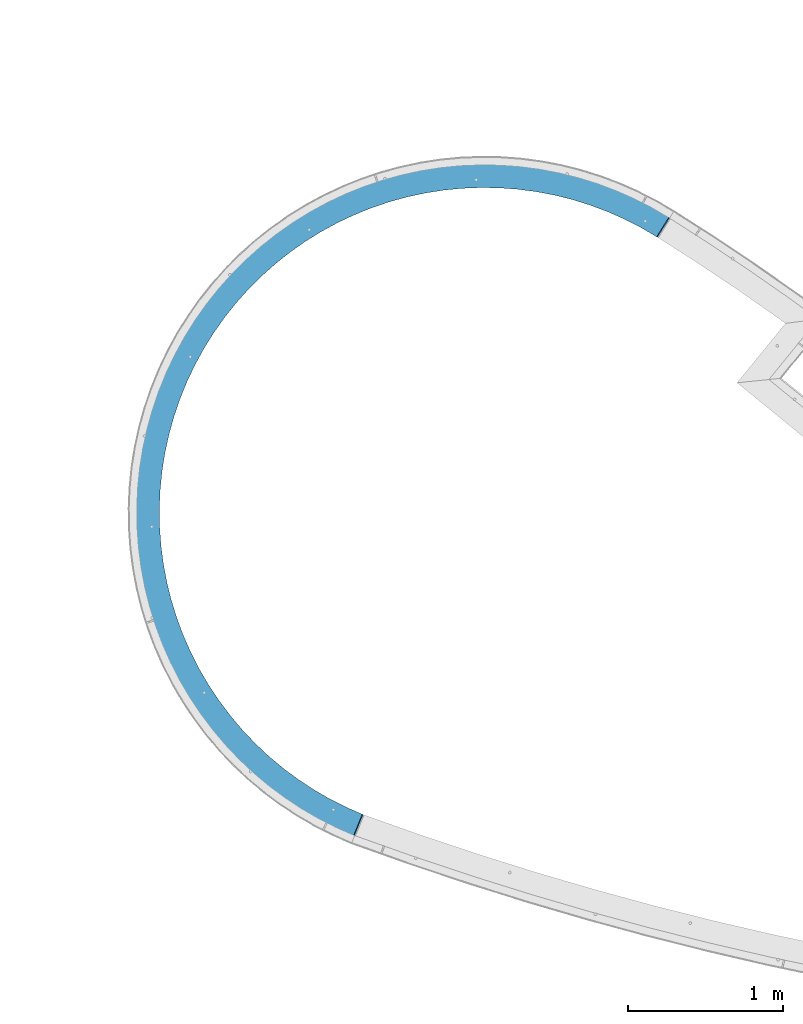
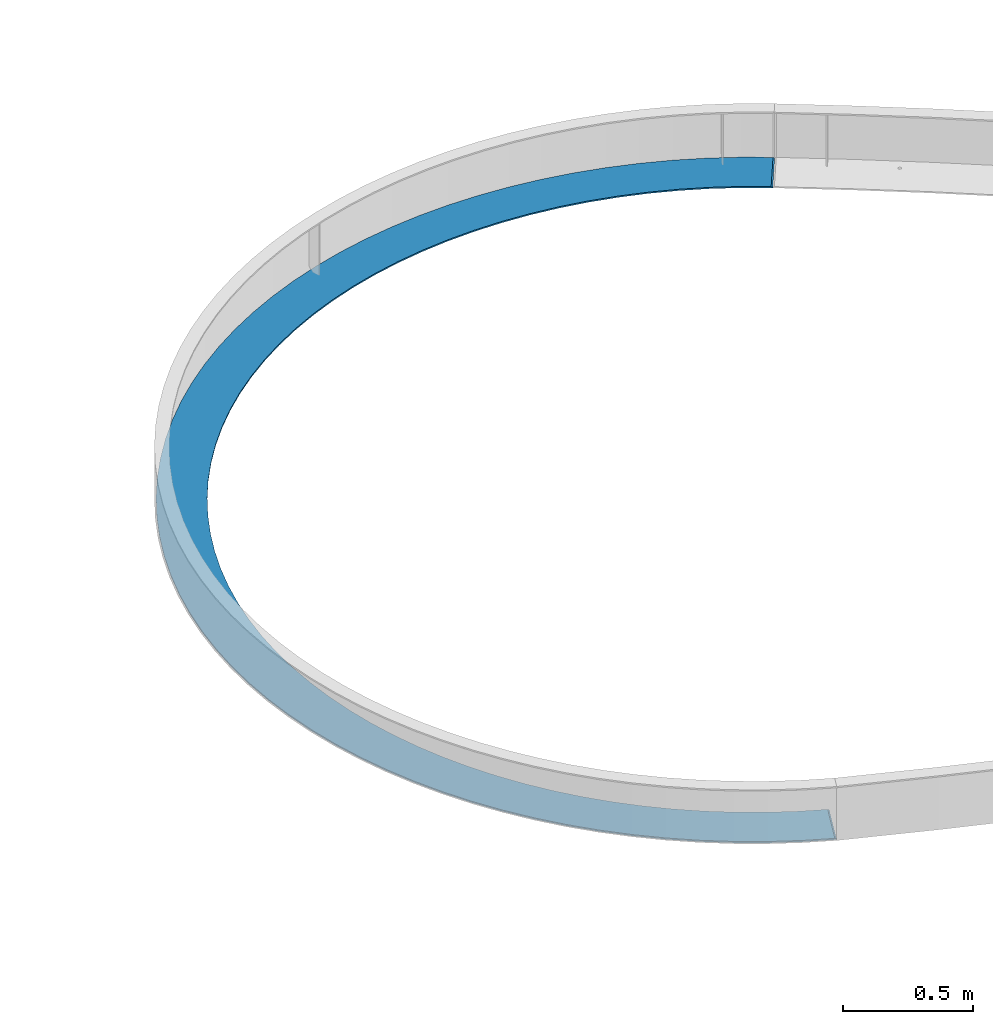
# One storey, part 1138 of 1763: 1 beam, 1 element without a shape of its own.
"""IFC2X3 building model written with IfcOpenShell, lengths in millimetres."""

from ifc_helpers import new_model, si_unit, frame, origin_with_axes, place, context, subcontext, project, spatial, faceted_brep, material, type_object, element, aggregate, save


model = new_model("IFC2X3")

# Units and contexts
model_context = context("Model", 3, precision=1e-05, world=origin_with_axes())
body_context = subcontext(model_context, "Body", "Model", "MODEL_VIEW")
ifc_project = project(units=[si_unit("LENGTHUNIT", "METRE", prefix="MILLI"), si_unit("AREAUNIT", "SQUARE_METRE"), si_unit("VOLUMEUNIT", "CUBIC_METRE"), si_unit("MASSUNIT", "GRAM", prefix="KILO"), si_unit("TIMEUNIT", "SECOND"), si_unit("PLANEANGLEUNIT", "RADIAN"), si_unit("SOLIDANGLEUNIT", "STERADIAN"), si_unit("THERMODYNAMICTEMPERATUREUNIT", "DEGREE_CELSIUS"), si_unit("LUMINOUSINTENSITYUNIT", "LUMEN")], contexts=[model_context])

# Site, building, storey
site_placement = place(None, origin_with_axes())
site = spatial("IfcSite", under=ifc_project, at=site_placement, CompositionType="ELEMENT")
building_placement = place(site_placement, origin_with_axes())
building = spatial("IfcBuilding", under=site, at=building_placement, Name="Undefined", CompositionType="ELEMENT")
storey_placement = place(building_placement, origin_with_axes())
storey = spatial("IfcBuildingStorey", under=building, at=storey_placement, Name="Undefined", CompositionType="ELEMENT", Elevation=0.0)

# Assembly, beam
assembly_placement = place(storey_placement, origin_with_axes())
assembly = element("IfcElementAssembly", 1, at=assembly_placement, inside=storey, Name="PLATE", AssemblyPlace="NOTDEFINED", PredefinedType="RIGID_FRAME")
ifc_material = material(Name="STEEL/A36")
beam_type = type_object("IfcBeamType", PredefinedType="NOTDEFINED")
beam_placement = place(assembly_placement, frame((-50997.2861487603, 62371.2138624728, -250.825), z_axis=(0.266272619084921, -0.963897760307418, 0.0), x_axis=(-0.963897760307417, -0.266272619084923, 0.0)))
beam = element("IfcBeam", 2, at=beam_placement, type_object=beam_type, material=ifc_material, Name="PLATE", context=body_context, shape_type="Brep", body=[
    faceted_brep([(3096.43633666375, -3.17500000001627, 3275.89225301459), (3091.50111386549, 3.49276660926989e-08, 3279.8921405202), (2971.98084869037, 3.49612605532457e-08, 3123.47977300199), (2976.91607149367, -3.17500000000001, 3119.47988549233), (145.222574236079, 3.17500000000001, 34.4671609732177), (5.59484760742635e-08, 3.17500000000001, -98.4250000019238), (5.59484760742635e-08, 2.91902608751116e-08, -98.4250000019238), (145.222574236079, 5.70412339584436e-08, 34.4671609732177), (3382.98923312408, 3.17500000000001, 3014.63504762789), (3290.94176959142, 3.17500000000001, 3108.56855966708), (3290.94176959142, -3.17500000000001, 3108.56855966708), (3382.98923312408, -3.17500000000001, 3014.63504762789), (3469.51402037893, 3.17500000000001, 2915.59111082551), (3469.51402037893, -3.17500000000001, 2915.59111082551), (3550.23290671136, 3.17500000000001, 2811.76095327933), (3550.23290671136, -3.17500000000001, 2811.76095327933), (3624.88167213745, 3.17500000000001, 2703.48444591426), (3624.88167213745, -3.17500000000001, 2703.48444591426), (3693.21596621459, 3.17500000000001, 2591.11601404929), (3693.21596621459, -3.17500000000001, 2591.11601404929), (3755.01210788247, 3.17500000000001, 2475.0234772445), (3755.01210788247, -3.17500000000001, 2475.0234772445), (3810.06781764621, 3.17500000000001, 2355.58684530426), (3810.06781764621, -3.17500000000001, 2355.58684530426), (3858.20287970485, 3.17500000000001, 2233.19707437785), (3858.20287970485, -3.17500000000001, 2233.19707437785), (3899.2597318583, 3.17500000000001, 2108.25478722868), (3899.2597318583, -3.17500000000001, 2108.25478722868), (3933.10398126108, 3.17500000000001, 1981.16896186183), (3933.10398126108, -3.17500000000001, 1981.16896186183), (3959.6248443353, 3.17500000000001, 1852.35559280174), (3959.6248443353, -3.17500000000001, 1852.35559280174), (3978.73550940238, 3.17500000000001, 1722.23632940272), (3978.73550940238, -3.17500000000001, 1722.23632940272), (3990.37342084682, 3.17500000000001, 1591.23709564915), (3990.37342084682, -3.17500000000001, 1591.23709564915), (3994.5004838817, 3.17500000000001, 1459.7866959635), (3994.5004838817, -3.17500000000001, 1459.7866959635), (3991.10318924573, 3.17500000000001, 1328.31541158563), (3991.10318924573, -3.17500000000001, 1328.31541158563), (3980.19265742351, 3.17500000000001, 1197.253592118), (3980.19265742351, -3.17500000000001, 1197.253592118), (3961.80460224453, 3.17500000000001, 1067.03024684708), (3961.80460224453, -3.17500000000001, 1067.03024684708), (3935.99921397978, 3.17500000000001, 938.071640452166), (3935.99921397978, -3.17500000000001, 938.071640452166), (3902.86096231887, 3.17500000000001, 810.79989769806), (3902.86096231887, -3.17500000000001, 810.79989769806), (3862.49831987233, 3.17500000000001, 685.631621679146), (3862.49831987233, -3.17500000000001, 685.631621679146), (3815.04340710444, 3.17500000000001, 562.976530137836), (3815.04340710444, -3.17500000000001, 562.976530137836), (3760.65155985864, 3.17500000000001, 443.236114320956), (3760.65155985864, -3.17500000000001, 443.236114320956), (3699.50082089117, 3.17500000000001, 326.802324764212), (3699.50082089117, -3.17500000000001, 326.802324764212), (3631.79135707745, 3.17500000000001, 214.056288306718), (3631.79135707745, -3.17500000000001, 214.056288306718), (3557.74480419886, 3.17500000000001, 105.367060535005), (3557.74480419886, -3.17500000000001, 105.367060535005), (3477.60354145432, 3.17500000000001, 1.09041774034267), (3477.60354145432, -3.17500000000001, 1.09041774034267), (3391.62989807488, -3.17500000000001, -98.4323076533037), (3391.62989807207, 3.17500000000001, -98.4323076564033), (3300.10529462127, 3.17500000000001, -192.875344404718), (3300.10529462127, -3.17500000000001, -192.875344404718), (3203.32932181517, 3.17500000000001, -281.929548772663), (3203.32932181517, -3.17500000000001, -281.929548772663), (3101.61875986926, 3.17500000000001, -365.303416482056), (3101.61875986926, -3.17500000000001, -365.303416482056), (2995.30654156124, 3.17500000000001, -442.724036904547), (2995.30654156124, -3.17500000000001, -442.724036904547), (2884.7406624333, 3.17500000000001, -513.937986386663), (2884.7406624333, -3.17500000000001, -513.937986386663), (2770.28304168589, 3.17500000000001, -578.712157790229), (2770.28304168589, -3.17500000000001, -578.712157790229), (2652.30833749492, 3.17500000000001, -636.834523530342), (2652.30833749492, -3.17500000000001, -636.834523530342), (2531.20272062982, 3.17500000000001, -688.114829612678), (2531.20272062982, -3.17500000000001, -688.114829612678), (2407.36261038716, 3.17500000000001, -732.385218398689), (2407.36261038716, -3.17500000000001, -732.385218398689), (2281.19337697738, 3.17500000000001, -769.500778059853), (2281.19337697738, -3.17500000000001, -769.500778059853), (2153.10801461204, 3.17500000000001, -799.340016922739), (2153.10801461204, -3.17500000000001, -799.340016922739), (2023.5257896354, 3.17500000000001, -821.80526115204), (2023.5257896354, -3.17500000000001, -821.80526115204), (1892.87086812502, 3.17500000000001, -836.822974469687), (1892.87086812502, -3.17500000000001, -836.822974469687), (1761.57092745391, 3.17500000000001, -844.343998863842), (1761.57092745391, -3.17500000000001, -844.343998863842), (1630.0557563591, 3.17500000000001, -844.343715499475), (1630.0557563591, -3.17500000000001, -844.343715499475), (1498.75584809901, 3.17500000000001, -836.82212530417), (1498.75584809901, -3.17500000000001, -836.82212530417), (1368.10099130457, 3.17500000000001, -821.803848964948), (1368.10099130457, -3.17500000000001, -821.803848964948), (1238.51886313698, 3.17500000000001, -799.338046336663), (1238.51886313698, -3.17500000000001, -799.338046336663), (1110.43362935688, 3.17500000000001, -769.498255525148), (1110.43362935688, -3.17500000000001, -769.498255525148), (984.264555887625, 3.17500000000001, -732.382152172489), (984.264555887625, -3.17500000000001, -732.382152172489), (860.424636417272, 3.17500000000001, -688.111229731774), (860.424636417272, -3.17500000000001, -688.111229731774), (739.319240531775, 3.17500000000001, -636.830401778323), (739.319240531775, -3.17500000000001, -636.830401778323), (621.344786804344, 3.17500000000001, -578.707527658989), (621.344786804344, -3.17500000000001, -578.707527658989), (506.887445184606, 3.17500000000001, -513.932863032154), (506.887445184606, -3.17500000000001, -513.932863032154), (396.321872934757, 3.17500000000001, -442.718437097254), (396.321872934757, -3.17500000000001, -442.718437097254), (290.009988250749, 3.17500000000001, -365.297358551994), (290.009988250749, -3.17500000000001, -365.297358551994), (188.299785582683, 3.17500000000001, -281.923052549508), (188.299785582683, -3.17500000000001, -281.923052549508), (91.524196532253, 3.17500000000001, -192.868431152761), (91.524196532253, -3.17500000000001, -192.868431152761), (4.4209089781034, -3.17500000000001, -102.986917216054), (149.643483135937, -3.17499998607698, 29.9052437820937), (228.909032748386, -3.17500000000001, -51.8885415301338), (228.909032748386, 3.17500000000001, -51.8885415301338), (317.397177194114, -3.17500000000001, -133.316908735491), (317.397177194114, 3.17500000000001, -133.316908735491), (410.397356202113, -3.17500000000001, -209.551398290147), (410.397356202113, 3.17500000000001, -209.551398290147), (507.605148999035, -3.17500000000001, -280.342469144642), (507.605148999035, 3.17500000000001, -280.342469144642), (608.702361880583, -3.17500000000001, -345.458398384435), (608.702361880583, 3.17500000000001, -345.458398384435), (713.358069766196, -3.17500000000001, -404.686039736567), (713.358069766196, 3.17500000000001, -404.686039736567), (821.229699427851, -3.17500000000001, -457.831521269036), (821.229699427851, 3.17500000000001, -457.831521269036), (931.964150847081, -3.17500000000001, -504.720879998495), (931.964150847081, 3.17500000000001, -504.720879998495), (1045.19895302977, -3.17500000000001, -545.200631329571), (1045.19895302977, 3.17500000000001, -545.200631329571), (1160.56345049525, -3.17500000000001, -579.138271461328), (1160.56345049525, 3.17500000000001, -579.138271461328), (1277.68001655604, -3.17500000000001, -606.422711116698), (1277.68001655604, 3.17500000000001, -606.422711116698), (1396.16528941656, -3.17500000000001, -626.964639174868), (1396.16528941656, 3.17500000000001, -626.964639174868), (1515.63142704488, -3.17500000000001, -640.696815016621), (1515.63142704488, 3.17500000000001, -640.696815016621), (1635.68737670977, -3.17500000000001, -647.574288625357), (1635.68737670977, 3.17500000000001, -647.574288625357), (1755.9401550274, -3.17500000000001, -647.57454772362), (1755.9401550274, 3.17500000000001, -647.57454772362), (1875.99613432777, -3.17500000000001, -640.697591463264), (1875.99613432777, 3.17500000000001, -640.697591463264), (1995.46233113004, -3.17500000000001, -626.965930428327), (1995.46233113004, 3.17500000000001, -626.965930428327), (2113.94769250928, -3.17500000000001, -606.424512950267), (2113.94769250928, 3.17500000000001, -606.424512950267), (2231.06437614382, -3.17500000000001, -579.140577977014), (2231.06437614382, 3.17500000000001, -579.140577977014), (2346.42901985324, -3.17500000000001, -545.20343497736), (2346.42901985324, 3.17500000000001, -545.20343497736), (2459.6639964713, -3.17500000000001, -504.724171601119), (2459.6639964713, 3.17500000000001, -504.724171601119), (2570.39864994638, -3.17500000000001, -457.835290051968), (2570.39864994638, 3.17500000000001, -457.835290051968), (2678.27050862297, -3.17500000000001, -404.690273363332), (2678.27050862297, 3.17500000000001, -404.690273363332), (2782.92647173296, -3.17500000000001, -345.463082996925), (2782.92647173296, 3.17500000000001, -345.463082996925), (2884.02396521288, -3.17500000000001, -280.347589408571), (2884.02396521288, 3.17500000000001, -280.347589408571), (2981.23206306368, -3.17500000000001, -209.556937445144), (2981.23206306368, 3.17500000000001, -209.556937445144), (3074.23257058254, -3.17500000000001, -133.322848650088), (3074.23257058254, 3.17500000000001, -133.322848650088), (3162.72106592073, -3.17500000000001, -51.8948627609789), (3162.72106592073, 3.17500000000001, -51.8948627609789), (3246.40789655856, -3.17500000000001, 34.4604791175952), (3246.40789655856, 3.17500000000001, 34.4604791175952), (3154.34226571007, -3.17500000000001, 2966.82760567163), (3065.40311240154, -3.17500000000001, 3047.7631213658), (3065.40311240154, 3.17500000000001, 3047.7631213658), (3154.34226571007, 3.17500000000001, 2966.82760567163), (3238.50718094154, -3.17500000000001, 2880.93815500394), (3238.50718094154, 3.17500000000001, 2880.93815500394), (3317.62235810384, -3.17500000000001, 2790.37591433767), (3317.62235810384, 3.17500000000001, 2790.37591433767), (3391.42882669097, -3.17500000000001, 2695.43732425642), (3391.42882669097, 3.17500000000001, 2695.43732425642), (3459.68499338035, -3.17500000000001, 2596.43315060304), (3459.68499338035, 3.17500000000001, 2596.43315060304), (3522.16743284883, -3.17500000000001, 2493.68746723879), (3522.16743284883, 3.17500000000001, 2493.68746723879), (3578.67161911862, -3.17500000000001, 2387.53659524093), (3578.67161911862, 3.17500000000001, 2387.53659524093), (3629.01259503947, -3.17500000000001, 2278.32800201103), (3629.01259503947, 3.17500000000001, 2278.32800201103), (3673.02557771542, -3.17500000000001, 2166.41916389766), (3673.02557771542, 3.17500000000001, 2166.41916389766), (3710.5664978945, -3.17500000000001, 2052.17639605643), (3710.5664978945, 3.17500000000001, 2052.17639605643), (3741.51247155566, -3.17500000000001, 1935.97365337762), (3741.51247155566, 3.17500000000001, 1935.97365337762), (3765.76220214944, -3.17500000000001, 1818.1913064064), (3765.76220214944, 3.17500000000001, 1818.1913064064), (3783.23631217548, -3.17500000000001, 1699.21489626258), (3783.23631217548, 3.17500000000001, 1699.21489626258), (3793.87760301177, -3.17500000000001, 1579.43387263505), (3793.87760301177, 3.17500000000001, 1579.43387263505), (3797.65124214484, -3.17500000000001, 1459.24031898259), (3797.65124214484, 3.17500000000001, 1459.24031898259), (3794.54487718832, -3.17500000000001, 1339.02766911297), (3794.54487718832, 3.17500000000001, 1339.02766911297), (3784.56867631646, -3.17500000000001, 1219.18941934236), (3784.56867631646, 3.17500000000001, 1219.18941934236), (3767.75529498019, -3.17500000000001, 1100.11784044985), (3767.75529498019, 3.17500000000001, 1100.11784044985), (3744.15976901496, -3.17500000000001, 982.202693643587), (3744.15976901496, 3.17500000000001, 982.202693643587), (3713.85933449, -3.17500000000001, 865.829954741756), (3713.85933449, 3.17500000000001, 865.829954741756), (3676.95317488871, -3.17500000000001, 751.380550744172), (3676.95317488871, 3.17500000000001, 751.380550744172), (3633.56209644787, -3.17500000000001, 639.229112930567), (3633.56209644787, 3.17500000000001, 639.229112930581), (3583.82813271836, -3.17500000000001, 529.742750566715), (3583.82813271836, 3.17500000000001, 529.742750566715), (3527.91407964166, -3.17500000000001, 423.279849232713), (3527.91407964166, 3.17500000000001, 423.279849232713), (3466.0029626642, -3.17500000000001, 320.188897706772), (3466.0029626642, 3.17500000000001, 320.188897706772), (3398.29743763364, -3.17500000000001, 220.807347244656), (3398.29743763364, 3.17500000000001, 220.807347244656), (3325.01912743833, -3.17500000000001, 125.460506988456), (3325.01912743833, 3.17500000000001, 125.460506988456), (2971.98084869037, 3.17500000000001, 3123.47977300199), (3091.50111386549, 3.17500000000001, 3279.8921405202), (3193.67293199708, 3.17500000000001, 3197.08417105775), (3193.67293199708, -3.17500000000001, 3197.08417105775)], [[[0, 1, 2, 3]], [[4, 5, 6, 7]], [[8, 9, 10, 11]], [[12, 8, 11, 13]], [[14, 12, 13, 15]], [[16, 14, 15, 17]], [[18, 16, 17, 19]], [[20, 18, 19, 21]], [[22, 20, 21, 23]], [[24, 22, 23, 25]], [[26, 24, 25, 27]], [[28, 26, 27, 29]], [[30, 28, 29, 31]], [[32, 30, 31, 33]], [[34, 32, 33, 35]], [[36, 34, 35, 37]], [[38, 36, 37, 39]], [[40, 38, 39, 41]], [[42, 40, 41, 43]], [[44, 42, 43, 45]], [[46, 44, 45, 47]], [[48, 46, 47, 49]], [[50, 48, 49, 51]], [[52, 50, 51, 53]], [[54, 52, 53, 55]], [[56, 54, 55, 57]], [[58, 56, 57, 59]], [[60, 58, 59, 61]], [[62, 63, 60, 61]], [[64, 63, 62, 65]], [[66, 64, 65, 67]], [[68, 66, 67, 69]], [[70, 68, 69, 71]], [[72, 70, 71, 73]], [[74, 72, 73, 75]], [[76, 74, 75, 77]], [[78, 76, 77, 79]], [[80, 78, 79, 81]], [[82, 80, 81, 83]], [[84, 82, 83, 85]], [[86, 84, 85, 87]], [[88, 86, 87, 89]], [[90, 88, 89, 91]], [[92, 90, 91, 93]], [[94, 92, 93, 95]], [[96, 94, 95, 97]], [[98, 96, 97, 99]], [[100, 98, 99, 101]], [[102, 100, 101, 103]], [[104, 102, 103, 105]], [[106, 104, 105, 107]], [[108, 106, 107, 109]], [[110, 108, 109, 111]], [[112, 110, 111, 113]], [[114, 112, 113, 115]], [[116, 114, 115, 117]], [[118, 116, 117, 119]], [[5, 118, 119, 120, 6]], [[121, 7, 6, 120]], [[122, 123, 4, 7, 121]], [[122, 124, 125, 123]], [[124, 126, 127, 125]], [[126, 128, 129, 127]], [[128, 130, 131, 129]], [[130, 132, 133, 131]], [[132, 134, 135, 133]], [[134, 136, 137, 135]], [[136, 138, 139, 137]], [[138, 140, 141, 139]], [[140, 142, 143, 141]], [[142, 144, 145, 143]], [[144, 146, 147, 145]], [[146, 148, 149, 147]], [[148, 150, 151, 149]], [[150, 152, 153, 151]], [[152, 154, 155, 153]], [[154, 156, 157, 155]], [[156, 158, 159, 157]], [[158, 160, 161, 159]], [[160, 162, 163, 161]], [[162, 164, 165, 163]], [[164, 166, 167, 165]], [[166, 168, 169, 167]], [[168, 170, 171, 169]], [[170, 172, 173, 171]], [[172, 174, 175, 173]], [[174, 176, 177, 175]], [[176, 178, 179, 177]], [[180, 181, 182, 183]], [[184, 180, 183, 185]], [[186, 184, 185, 187]], [[188, 186, 187, 189]], [[190, 188, 189, 191]], [[192, 190, 191, 193]], [[194, 192, 193, 195]], [[196, 194, 195, 197]], [[198, 196, 197, 199]], [[200, 198, 199, 201]], [[202, 200, 201, 203]], [[204, 202, 203, 205]], [[206, 204, 205, 207]], [[208, 206, 207, 209]], [[210, 208, 209, 211]], [[212, 210, 211, 213]], [[214, 212, 213, 215]], [[216, 214, 215, 217]], [[218, 216, 217, 219]], [[220, 218, 219, 221]], [[222, 220, 221, 223]], [[224, 222, 223, 225]], [[226, 224, 225, 227]], [[228, 226, 227, 229]], [[230, 228, 229, 231]], [[232, 230, 231, 233]], [[234, 232, 233, 235]], [[179, 178, 234, 235]], [[233, 231, 229, 227, 225, 223, 221, 219, 217, 215, 213, 211, 209, 207, 205, 203, 201, 199, 197, 195, 193, 191, 189, 187, 185, 183, 182, 236, 237, 238, 9, 8, 12, 14, 16, 18, 20, 22, 24, 26, 28, 30, 32, 34, 36, 38, 40, 42, 44, 46, 48, 50, 52, 54, 56, 58, 60, 63, 64, 66, 68, 70, 72, 74, 76, 78, 80, 82, 84, 86, 88, 90, 92, 94, 96, 98, 100, 102, 104, 106, 108, 110, 112, 114, 116, 118, 5, 4, 123, 125, 127, 129, 131, 133, 135, 137, 139, 141, 143, 145, 147, 149, 151, 153, 155, 157, 159, 161, 163, 165, 167, 169, 171, 173, 175, 177, 179, 235]], [[9, 238, 239, 10]], [[181, 180, 184, 186, 188, 190, 192, 194, 196, 198, 200, 202, 204, 206, 208, 210, 212, 214, 216, 218, 220, 222, 224, 226, 228, 230, 232, 234, 178, 176, 174, 172, 170, 168, 166, 164, 162, 160, 158, 156, 154, 152, 150, 148, 146, 144, 142, 140, 138, 136, 134, 132, 130, 128, 126, 124, 122, 121, 120, 119, 117, 115, 113, 111, 109, 107, 105, 103, 101, 99, 97, 95, 93, 91, 89, 87, 85, 83, 81, 79, 77, 75, 73, 71, 69, 67, 65, 62, 61, 59, 57, 55, 53, 51, 49, 47, 45, 43, 41, 39, 37, 35, 33, 31, 29, 27, 25, 23, 21, 19, 17, 15, 13, 11, 10, 239, 0, 3]], [[236, 182, 181, 3, 2]], [[237, 236, 2, 1]], [[239, 238, 237, 1, 0]]]),
])
aggregate(assembly, [beam])

save(model, "model.ifc")
